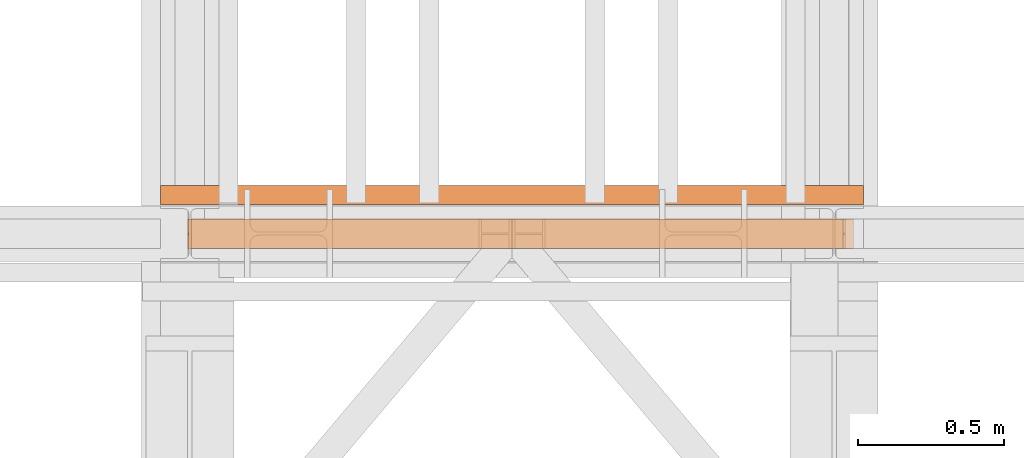
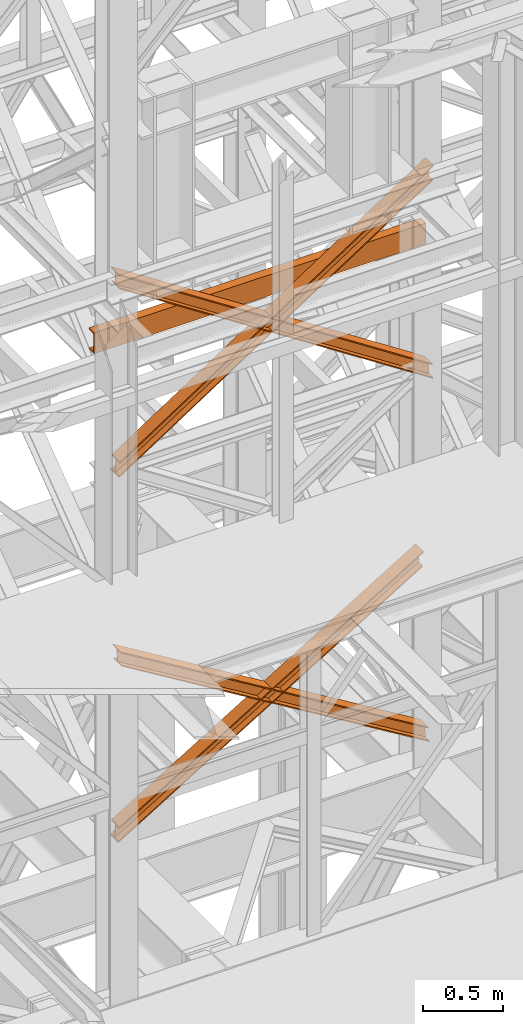
# One storey, part 148 of 208: 5 proxies.
"""IFC2X3 building model written with IfcOpenShell, lengths in millimetres."""

from ifc_helpers import new_model, entity, si_unit, converted_unit, frame, origin, origin_with_axes, place, context, subcontext, project, spatial, faceted_brep, element, save


model = new_model("IFC2X3")

# Units and contexts
model_context = context("Model", 3, precision=1e-05, world=origin())
plan_context = context("Plan", 3, precision=1e-05, world=origin())
body_context = subcontext(model_context, "Body", "Model", "MODEL_VIEW")
ifc_project = project(units=[si_unit("LENGTHUNIT", "METRE", prefix="MILLI"), converted_unit("PLANEANGLEUNIT", "DEGREE", entity("IfcPlaneAngleMeasure", 0.0174532925199433), si_unit("PLANEANGLEUNIT", "RADIAN"), dimensions=[0, 0, 0, 0, 0, 0, 0]), si_unit("AREAUNIT", "SQUARE_METRE"), si_unit("VOLUMEUNIT", "CUBIC_METRE")], contexts=[model_context, plan_context])

# Building, storey
building_placement = place(None, origin())
building = spatial("IfcBuilding", under=ifc_project, at=building_placement, CompositionType="COMPLEX")
storey_placement = place(building_placement, origin_with_axes())
storey = spatial("IfcBuildingStorey", under=building, at=storey_placement, Name="Geschoss", CompositionType="ELEMENT")

# Proxies
proxy_1_placement = place(storey_placement, frame((3296.815108748539, -16012.57439031789, 5416.11849569985), z_axis=(0.0, 0.0, 1.0), x_axis=(1.0, 0.0, 0.0)))
element("IfcBuildingElementProxy", 1, at=proxy_1_placement, inside=storey, context=body_context, shape_type="Brep", body=[
    faceted_brep([(9.078306774576959, 0.00999999999839929, 1356.319280613212), (8.32261454336276, 0.00999999999839929, 1365.972310985451), (2235.078850609916, 0.01000000000021828, 9.663030372239518), (2235.834542841132, 0.01000000000021828, 0.01000000000021828), (9.078306774576959, 100.0099999999984, 1356.319280613212), (9.078306774576959, 0.00999999999839929, 1356.319280613212), (2235.834542841132, 0.01000000000021828, 0.01000000000021828), (2235.834542841132, 100.0100000000002, 0.01000000000021828), (8.32261454336276, 100.0099999999984, 1365.972310985451), (9.078306774576959, 100.0099999999984, 1356.319280613212), (2235.834542841132, 100.0100000000002, 0.01000000000021828), (2235.078850609916, 100.0100000000002, 9.663030372239518), (8.32261454336276, 52.5099999999984, 1365.972310985451), (8.32261454336276, 100.0099999999984, 1365.972310985451), (2235.078850609916, 100.0100000000002, 9.663030372239518), (2235.078850609916, 52.51000000000022, 9.663030372239518), (0.7656922312153256, 52.5099999999984, 1462.502614707844), (8.32261454336276, 52.5099999999984, 1365.972310985451), (2235.078850609916, 52.51000000000022, 9.663030372239518), (2227.521928297769, 52.51000000000022, 106.1933340946398), (0.7656922312135066, 100.0099999999984, 1462.502614707844), (0.7656922312153256, 52.5099999999984, 1462.502614707844), (2227.521928297769, 52.51000000000022, 106.1933340946398), (2227.521928297765, 100.0100000000002, 106.1933340946398), (0.009999999999308784, 100.0099999999984, 1472.155645080084), (0.7656922312135066, 100.0099999999984, 1462.502614707844), (2227.521928297765, 100.0100000000002, 106.1933340946398), (2226.766236066553, 100.0100000000002, 115.8463644668791), (0.01000000000112777, 0.00999999999839929, 1472.155645080084), (0.009999999999308784, 100.0099999999984, 1472.155645080084), (2226.766236066553, 100.0100000000002, 115.8463644668791), (2226.766236066553, 0.01000000000021828, 115.8463644668791), (0.7656922312135066, 0.00999999999839929, 1462.502614707844), (0.01000000000112777, 0.00999999999839929, 1472.155645080084), (2226.766236066553, 0.01000000000021828, 115.8463644668791), (2227.521928297769, 0.01000000000021828, 106.1933340946398), (0.7656922312135066, 47.5099999999984, 1462.502614707844), (0.7656922312135066, 0.00999999999839929, 1462.502614707844), (2227.521928297769, 0.01000000000021828, 106.1933340946398), (2227.521928297769, 47.51000000000022, 106.1933340946398), (8.32261454336276, 47.5099999999984, 1365.972310985451), (0.7656922312135066, 47.5099999999984, 1462.502614707844), (2227.521928297769, 47.51000000000022, 106.1933340946398), (2235.078850609916, 47.51000000000022, 9.663030372239518), (8.32261454336276, 0.00999999999839929, 1365.972310985451), (8.32261454336276, 47.5099999999984, 1365.972310985451), (2235.078850609916, 47.51000000000022, 9.663030372239518), (2235.078850609916, 0.01000000000021828, 9.663030372239518), (8.32261454336276, 0.00999999999839929, 1365.972310985451), (9.078306774576959, 0.00999999999839929, 1356.319280613212), (9.078306774576959, 100.0099999999984, 1356.319280613212), (8.32261454336276, 100.0099999999984, 1365.972310985451), (8.32261454336276, 52.5099999999984, 1365.972310985451), (0.7656922312153256, 52.5099999999984, 1462.502614707844), (0.7656922312135066, 100.0099999999984, 1462.502614707844), (0.009999999999308784, 100.0099999999984, 1472.155645080084), (0.01000000000112777, 0.00999999999839929, 1472.155645080084), (0.7656922312135066, 0.00999999999839929, 1462.502614707844), (0.7656922312135066, 47.5099999999984, 1462.502614707844), (8.32261454336276, 47.5099999999984, 1365.972310985451), (2235.834542841132, 0.01000000000021828, 0.01000000000021828), (2235.078850609916, 0.01000000000021828, 9.663030372239518), (2235.078850609916, 47.51000000000022, 9.663030372239518), (2227.521928297769, 47.51000000000022, 106.1933340946398), (2227.521928297769, 0.01000000000021828, 106.1933340946398), (2226.766236066553, 0.01000000000021828, 115.8463644668791), (2226.766236066553, 100.0100000000002, 115.8463644668791), (2227.521928297765, 100.0100000000002, 106.1933340946398), (2227.521928297769, 52.51000000000022, 106.1933340946398), (2235.078850609916, 52.51000000000022, 9.663030372239518), (2235.078850609916, 100.0100000000002, 9.663030372239518), (2235.834542841132, 100.0100000000002, 0.01000000000021828)], [[[0, 1, 2, 3]], [[4, 5, 6, 7]], [[8, 9, 10, 11]], [[12, 13, 14, 15]], [[16, 17, 18, 19]], [[20, 21, 22, 23]], [[24, 25, 26, 27]], [[28, 29, 30, 31]], [[32, 33, 34, 35]], [[36, 37, 38, 39]], [[40, 41, 42, 43]], [[44, 45, 46, 47]], [[48, 49, 50, 51, 52, 53, 54, 55, 56, 57, 58, 59]], [[60, 61, 62, 63, 64, 65, 66, 67, 68, 69, 70, 71]]], orient=[[False], [False], [False], [False], [False], [False], [False], [False], [False], [False], [False], [False], [False], [False]]),
])
proxy_2_placement = place(storey_placement, frame((3281.320778471448, -16012.57439031789, 5432.838493073343), z_axis=(0.0, 0.0, 1.0), x_axis=(1.0, 0.0, 0.0)))
element("IfcBuildingElementProxy", 2, at=proxy_2_placement, inside=storey, context=body_context, shape_type="Brep", body=[
    faceted_brep([(2199.315743062771, 0.01000000000021828, 1339.599283239715), (0.01000000000021828, 0.01000000000385626, 0.01000000000021828), (0.7656922312144161, 0.01000000000385626, 9.663030372239518), (2200.071435293985, 0.01000000000021828, 1349.252313611954), (2199.315743062771, 100.0100000000002, 1339.599283239715), (0.01000000000021828, 100.0100000000039, 0.01000000000021828), (0.01000000000021828, 0.01000000000385626, 0.01000000000021828), (2199.315743062771, 0.01000000000021828, 1339.599283239715), (2200.071435293985, 100.0100000000002, 1349.252313611954), (0.7656922312144161, 100.0100000000039, 9.663030372239518), (0.01000000000021828, 100.0100000000039, 0.01000000000021828), (2199.315743062771, 100.0100000000002, 1339.599283239715), (2200.071435293985, 52.51000000000022, 1349.252313611954), (0.7656922312144161, 52.51000000000386, 9.663030372239518), (0.7656922312144161, 100.0100000000039, 9.663030372239518), (2200.071435293985, 100.0100000000002, 1349.252313611954), (2207.628357606132, 52.51000000000022, 1445.782617334351), (8.32261454336367, 52.51000000000386, 106.1933340946362), (0.7656922312144161, 52.51000000000386, 9.663030372239518), (2200.071435293985, 52.51000000000022, 1349.252313611954), (2207.628357606134, 100.0100000000002, 1445.782617334351), (8.32261454336549, 100.0100000000039, 106.1933340946362), (8.32261454336367, 52.51000000000386, 106.1933340946362), (2207.628357606132, 52.51000000000022, 1445.782617334351), (2208.384049837348, 100.0100000000002, 1455.43564770659), (9.078306774579687, 100.0100000000039, 115.8463644668791), (8.32261454336549, 100.0100000000039, 106.1933340946362), (2207.628357606134, 100.0100000000002, 1445.782617334351), (2208.384049837347, 0.01000000000021828, 1455.43564770659), (9.078306774579687, 0.01000000000385626, 115.8463644668791), (9.078306774579687, 100.0100000000039, 115.8463644668791), (2208.384049837348, 100.0100000000002, 1455.43564770659), (2207.628357606134, 0.01000000000021828, 1445.782617334351), (8.32261454336367, 0.01000000000385626, 106.1933340946362), (9.078306774579687, 0.01000000000385626, 115.8463644668791), (2208.384049837347, 0.01000000000021828, 1455.43564770659), (2207.628357606134, 47.51000000000022, 1445.782617334351), (8.32261454336367, 47.51000000000386, 106.1933340946362), (8.32261454336367, 0.01000000000385626, 106.1933340946362), (2207.628357606134, 0.01000000000021828, 1445.782617334351), (2200.071435293985, 47.51000000000022, 1349.252313611954), (0.7656922312144161, 47.51000000000386, 9.663030372239518), (8.32261454336367, 47.51000000000386, 106.1933340946362), (2207.628357606134, 47.51000000000022, 1445.782617334351), (2200.071435293985, 0.01000000000021828, 1349.252313611954), (0.7656922312144161, 0.01000000000385626, 9.663030372239518), (0.7656922312144161, 47.51000000000386, 9.663030372239518), (2200.071435293985, 47.51000000000022, 1349.252313611954), (2200.071435293985, 0.01000000000021828, 1349.252313611954), (2200.071435293985, 47.51000000000022, 1349.252313611954), (2207.628357606134, 47.51000000000022, 1445.782617334351), (2207.628357606134, 0.01000000000021828, 1445.782617334351), (2208.384049837347, 0.01000000000021828, 1455.43564770659), (2208.384049837348, 100.0100000000002, 1455.43564770659), (2207.628357606134, 100.0100000000002, 1445.782617334351), (2207.628357606132, 52.51000000000022, 1445.782617334351), (2200.071435293985, 52.51000000000022, 1349.252313611954), (2200.071435293985, 100.0100000000002, 1349.252313611954), (2199.315743062771, 100.0100000000002, 1339.599283239715), (2199.315743062771, 0.01000000000021828, 1339.599283239715), (0.01000000000021828, 0.01000000000385626, 0.01000000000021828), (0.01000000000021828, 100.0100000000039, 0.01000000000021828), (0.7656922312144161, 100.0100000000039, 9.663030372239518), (0.7656922312144161, 52.51000000000386, 9.663030372239518), (8.32261454336367, 52.51000000000386, 106.1933340946362), (8.32261454336549, 100.0100000000039, 106.1933340946362), (9.078306774579687, 100.0100000000039, 115.8463644668791), (9.078306774579687, 0.01000000000385626, 115.8463644668791), (8.32261454336367, 0.01000000000385626, 106.1933340946362), (8.32261454336367, 47.51000000000386, 106.1933340946362), (0.7656922312144161, 47.51000000000386, 9.663030372239518), (0.7656922312144161, 0.01000000000385626, 9.663030372239518)], [[[0, 1, 2, 3]], [[4, 5, 6, 7]], [[8, 9, 10, 11]], [[12, 13, 14, 15]], [[16, 17, 18, 19]], [[20, 21, 22, 23]], [[24, 25, 26, 27]], [[28, 29, 30, 31]], [[32, 33, 34, 35]], [[36, 37, 38, 39]], [[40, 41, 42, 43]], [[44, 45, 46, 47]], [[48, 49, 50, 51, 52, 53, 54, 55, 56, 57, 58, 59]], [[60, 61, 62, 63, 64, 65, 66, 67, 68, 69, 70, 71]]], orient=[[False], [False], [False], [False], [False], [False], [False], [False], [False], [False], [False], [False], [False], [False]]),
])
proxy_3_placement = place(storey_placement, frame((3285.388188692425, -16012.57439031789, 8182.880142734512), z_axis=(0.0, 0.0, 1.0), x_axis=(1.0, 0.0, 0.0)))
element("IfcBuildingElementProxy", 3, at=proxy_3_placement, inside=storey, context=body_context, shape_type="Brep", body=[
    faceted_brep([(5.514462924551481, 0.01000000000021828, 1478.089754817496), (5.055757680838724, 0.01000000000021828, 1487.761448341129), (2271.874000004331, 0.01000000000021828, 9.68169352363293), (2272.332705248044, 0.01000000000021828, 0.01000000000021828), (5.514462924551481, 100.0100000000002, 1478.089754817496), (5.514462924551481, 0.01000000000021828, 1478.089754817496), (2272.332705248044, 0.01000000000021828, 0.01000000000021828), (2272.332705248044, 100.0100000000002, 0.01000000000021828), (5.055757680838724, 100.0100000000002, 1487.761448341129), (5.514462924551481, 100.0100000000002, 1478.089754817496), (2272.332705248044, 100.0100000000002, 0.01000000000021828), (2271.874000004331, 100.0100000000002, 9.68169352363293), (5.055757680838724, 52.51000000000022, 1487.761448341129), (5.055757680838724, 100.0100000000002, 1487.761448341129), (2271.874000004331, 100.0100000000002, 9.68169352363293), (2271.874000004331, 52.51000000000022, 9.68169352363293), (0.4687052437147941, 52.51000000000022, 1584.478383577456), (5.055757680838724, 52.51000000000022, 1487.761448341129), (2271.874000004331, 52.51000000000022, 9.68169352363293), (2267.286947567205, 52.51000000000022, 106.3986287599673), (0.4687052437129751, 100.0100000000002, 1584.478383577456), (0.4687052437147941, 52.51000000000022, 1584.478383577456), (2267.286947567205, 52.51000000000022, 106.3986287599673), (2267.286947567203, 100.0100000000002, 106.3986287599673), (0.01000000000021828, 100.0100000000002, 1594.150077101096), (0.4687052437129751, 100.0100000000002, 1584.478383577456), (2267.286947567203, 100.0100000000002, 106.3986287599673), (2266.828242323492, 100.0100000000002, 116.0703222836), (0.01000000000203727, 0.01000000000021828, 1594.150077101096), (0.01000000000021828, 100.0100000000002, 1594.150077101096), (2266.828242323492, 100.0100000000002, 116.0703222836), (2266.828242323492, 0.01000000000021828, 116.0703222836), (0.4687052437129751, 0.01000000000021828, 1584.478383577456), (0.01000000000203727, 0.01000000000021828, 1594.150077101096), (2266.828242323492, 0.01000000000021828, 116.0703222836), (2267.286947567205, 0.01000000000021828, 106.3986287599673), (0.4687052437129751, 47.51000000000022, 1584.478383577456), (0.4687052437129751, 0.01000000000021828, 1584.478383577456), (2267.286947567205, 0.01000000000021828, 106.3986287599673), (2267.286947567205, 47.51000000000022, 106.3986287599673), (5.055757680838724, 47.51000000000022, 1487.761448341129), (0.4687052437129751, 47.51000000000022, 1584.478383577456), (2267.286947567205, 47.51000000000022, 106.3986287599673), (2271.874000004331, 47.51000000000022, 9.68169352363293), (5.055757680838724, 0.01000000000021828, 1487.761448341129), (5.055757680838724, 47.51000000000022, 1487.761448341129), (2271.874000004331, 47.51000000000022, 9.68169352363293), (2271.874000004331, 0.01000000000021828, 9.68169352363293), (5.055757680838724, 0.01000000000021828, 1487.761448341129), (5.514462924551481, 0.01000000000021828, 1478.089754817496), (5.514462924551481, 100.0100000000002, 1478.089754817496), (5.055757680838724, 100.0100000000002, 1487.761448341129), (5.055757680838724, 52.51000000000022, 1487.761448341129), (0.4687052437147941, 52.51000000000022, 1584.478383577456), (0.4687052437129751, 100.0100000000002, 1584.478383577456), (0.01000000000021828, 100.0100000000002, 1594.150077101096), (0.01000000000203727, 0.01000000000021828, 1594.150077101096), (0.4687052437129751, 0.01000000000021828, 1584.478383577456), (0.4687052437129751, 47.51000000000022, 1584.478383577456), (5.055757680838724, 47.51000000000022, 1487.761448341129), (2272.332705248044, 0.01000000000021828, 0.01000000000021828), (2271.874000004331, 0.01000000000021828, 9.68169352363293), (2271.874000004331, 47.51000000000022, 9.68169352363293), (2267.286947567205, 47.51000000000022, 106.3986287599673), (2267.286947567205, 0.01000000000021828, 106.3986287599673), (2266.828242323492, 0.01000000000021828, 116.0703222836), (2266.828242323492, 100.0100000000002, 116.0703222836), (2267.286947567203, 100.0100000000002, 106.3986287599673), (2267.286947567205, 52.51000000000022, 106.3986287599673), (2271.874000004331, 52.51000000000022, 9.68169352363293), (2271.874000004331, 100.0100000000002, 9.68169352363293), (2272.332705248044, 100.0100000000002, 0.01000000000021828)], [[[0, 1, 2, 3]], [[4, 5, 6, 7]], [[8, 9, 10, 11]], [[12, 13, 14, 15]], [[16, 17, 18, 19]], [[20, 21, 22, 23]], [[24, 25, 26, 27]], [[28, 29, 30, 31]], [[32, 33, 34, 35]], [[36, 37, 38, 39]], [[40, 41, 42, 43]], [[44, 45, 46, 47]], [[48, 49, 50, 51, 52, 53, 54, 55, 56, 57, 58, 59]], [[60, 61, 62, 63, 64, 65, 66, 67, 68, 69, 70, 71]]], orient=[[False], [False], [False], [False], [False], [False], [False], [False], [False], [False], [False], [False], [False], [False]]),
])
proxy_4_placement = place(storey_placement, frame((3287.437718684576, -16012.57439031789, 8221.109787353123), z_axis=(0.0, 0.0, 1.0), x_axis=(1.0, 0.0, 0.0)))
element("IfcBuildingElementProxy", 4, at=proxy_4_placement, inside=storey, context=body_context, shape_type="Brep", body=[
    faceted_brep([(2266.828242323492, 0.01000000000021828, 1478.089754817493), (0.01000000000021828, 0.01000000000203727, 0.01000000000021828), (0.4687052437129751, 0.01000000000203727, 9.68169352363293), (2267.286947567205, 0.01000000000021828, 1487.761448341124), (2266.828242323492, 100.0100000000002, 1478.089754817491), (0.01000000000021828, 100.010000000002, 0.01000000000021828), (0.01000000000021828, 0.01000000000203727, 0.01000000000021828), (2266.828242323492, 0.01000000000021828, 1478.089754817493), (2267.286947567205, 100.0100000000002, 1487.761448341124), (0.4687052437129751, 100.010000000002, 9.68169352363293), (0.01000000000021828, 100.010000000002, 0.01000000000021828), (2266.828242323492, 100.0100000000002, 1478.089754817491), (2267.286947567205, 52.51000000000022, 1487.761448341124), (0.4687052437129751, 52.51000000000204, 9.68169352363293), (0.4687052437129751, 100.010000000002, 9.68169352363293), (2267.286947567205, 100.0100000000002, 1487.761448341124), (2271.874000004329, 52.51000000000022, 1584.478383577458), (5.055757680838724, 52.51000000000022, 106.3986287599673), (0.4687052437129751, 52.51000000000204, 9.68169352363293), (2267.286947567205, 52.51000000000022, 1487.761448341124), (2271.874000004331, 100.0100000000002, 1584.478383577456), (5.055757680840543, 100.0100000000002, 106.3986287599673), (5.055757680838724, 52.51000000000022, 106.3986287599673), (2271.874000004329, 52.51000000000022, 1584.478383577458), (2272.332705248044, 100.0100000000002, 1594.150077101092), (5.514462924551481, 100.0100000000002, 116.0703222836), (5.055757680840543, 100.0100000000002, 106.3986287599673), (2271.874000004331, 100.0100000000002, 1584.478383577456), (2272.332705248042, 0.01000000000021828, 1594.150077101092), (5.514462924551481, 0.01000000000021828, 116.0703222836), (5.514462924551481, 100.0100000000002, 116.0703222836), (2272.332705248044, 100.0100000000002, 1594.150077101092), (2271.874000004331, 0.01000000000021828, 1584.478383577456), (5.055757680838724, 0.01000000000021828, 106.3986287599673), (5.514462924551481, 0.01000000000021828, 116.0703222836), (2272.332705248042, 0.01000000000021828, 1594.150077101092), (2271.874000004331, 47.51000000000022, 1584.478383577456), (5.055757680838724, 47.51000000000022, 106.3986287599673), (5.055757680838724, 0.01000000000021828, 106.3986287599673), (2271.874000004331, 0.01000000000021828, 1584.478383577456), (2267.286947567205, 47.51000000000022, 1487.761448341124), (0.4687052437129751, 47.51000000000204, 9.68169352363293), (5.055757680838724, 47.51000000000022, 106.3986287599673), (2271.874000004331, 47.51000000000022, 1584.478383577456), (2267.286947567205, 0.01000000000021828, 1487.761448341124), (0.4687052437129751, 0.01000000000203727, 9.68169352363293), (0.4687052437129751, 47.51000000000204, 9.68169352363293), (2267.286947567205, 47.51000000000022, 1487.761448341124), (2267.286947567205, 0.01000000000021828, 1487.761448341124), (2267.286947567205, 47.51000000000022, 1487.761448341124), (2271.874000004331, 47.51000000000022, 1584.478383577456), (2271.874000004331, 0.01000000000021828, 1584.478383577456), (2272.332705248042, 0.01000000000021828, 1594.150077101092), (2272.332705248044, 100.0100000000002, 1594.150077101092), (2271.874000004331, 100.0100000000002, 1584.478383577456), (2271.874000004329, 52.51000000000022, 1584.478383577458), (2267.286947567205, 52.51000000000022, 1487.761448341124), (2267.286947567205, 100.0100000000002, 1487.761448341124), (2266.828242323492, 100.0100000000002, 1478.089754817491), (2266.828242323492, 0.01000000000021828, 1478.089754817493), (0.01000000000021828, 0.01000000000203727, 0.01000000000021828), (0.01000000000021828, 100.010000000002, 0.01000000000021828), (0.4687052437129751, 100.010000000002, 9.68169352363293), (0.4687052437129751, 52.51000000000204, 9.68169352363293), (5.055757680838724, 52.51000000000022, 106.3986287599673), (5.055757680840543, 100.0100000000002, 106.3986287599673), (5.514462924551481, 100.0100000000002, 116.0703222836), (5.514462924551481, 0.01000000000021828, 116.0703222836), (5.055757680838724, 0.01000000000021828, 106.3986287599673), (5.055757680838724, 47.51000000000022, 106.3986287599673), (0.4687052437129751, 47.51000000000204, 9.68169352363293), (0.4687052437129751, 0.01000000000203727, 9.68169352363293)], [[[0, 1, 2, 3]], [[4, 5, 6, 7]], [[8, 9, 10, 11]], [[12, 13, 14, 15]], [[16, 17, 18, 19]], [[20, 21, 22, 23]], [[24, 25, 26, 27]], [[28, 29, 30, 31]], [[32, 33, 34, 35]], [[36, 37, 38, 39]], [[40, 41, 42, 43]], [[44, 45, 46, 47]], [[48, 49, 50, 51, 52, 53, 54, 55, 56, 57, 58, 59]], [[60, 61, 62, 63, 64, 65, 66, 67, 68, 69, 70, 71]]], orient=[[False], [False], [False], [False], [False], [False], [False], [False], [False], [False], [False], [False], [False], [False]]),
])
proxy_5_placement = place(storey_placement, frame((3193.302372304859, -15862.57438797436, 9109.989999999998), z_axis=(0.0, 0.0, 1.0), x_axis=(1.0, 0.0, 0.0)))
element("IfcBuildingElementProxy", 5, at=proxy_5_placement, inside=storey, context=body_context, shape_type="Brep", body=[
    faceted_brep([(2399.962597713924, 0.01853275732537441, 160.0100000000002), (0.009999999999308784, 0.00999999999839929, 160.0100000000002), (0.009999999999308784, 65.0099999999984, 160.0100000000002), (2399.962597713924, 65.01853275732537, 160.0100000000002), (2399.962597713924, 65.01853275732537, 160.0100000000002), (0.009999999999308784, 65.0099999999984, 160.0100000000002), (0.009999999999308784, 65.0099999999984, 156.8875719297539), (2399.962597713924, 65.01853275732537, 156.8875719297539), (2399.962597713924, 65.01853275732537, 156.8875719297539), (0.009999999999308784, 65.0099999999984, 156.8875719297539), (0.009999999999308784, 64.76726342282564, 155.2717110918293), (2399.962597713924, 64.77579618015261, 155.2717110918293), (2399.962597713924, 64.77579618015261, 155.2717110918293), (0.009999999999308784, 64.76726342282564, 155.2717110918293), (0.009999999999308784, 64.06053228585733, 153.7984655565542), (2399.962597713924, 64.06906504318067, 153.7984655565542), (2399.962597713924, 64.06906504318067, 153.7984655565542), (0.009999999999308784, 64.06053228585733, 153.7984655565542), (0.009999999999308784, 62.9521516384666, 152.5978732961266), (2399.962597713924, 62.96068439579358, 152.5978732961266), (2399.962597713924, 62.96068439579358, 152.5978732961266), (0.009999999999308784, 62.9521516384666, 152.5978732961266), (0.009999999999308784, 61.5399564114814, 151.7759086082897), (2399.962597713924, 61.54848916880837, 151.7759086082897), (2399.962597713924, 61.54848916880837, 151.7759086082897), (0.009999999999308784, 61.5399564114814, 151.7759086082897), (0.009999999999308784, 59.94859872255256, 151.4050878978051), (2399.962597713924, 59.95713147987954, 151.4050878978051), (2399.962597713924, 59.95713147987954, 151.4050878978051), (0.009999999999308784, 59.94859872255256, 151.4050878978051), (0.009999999999308784, 17.17267516602806, 147.9830140132835), (2399.962597713924, 17.18120792335503, 147.9830140132835), (2399.962597713924, 17.18120792335503, 147.9830140132835), (0.009999999999308784, 17.17267516602806, 147.9830140132835), (0.009999999999308784, 14.20840820800731, 147.318026761528), (2399.962597713924, 14.21694096533429, 147.318026761528), (2399.962597713924, 14.21694096533429, 147.318026761528), (0.009999999999308784, 14.20840820800731, 147.318026761528), (0.009999999999308784, 11.43861959928836, 145.7058782528511), (2399.962597713924, 11.4471523566117, 145.7058782528511), (2399.962597713924, 11.4471523566117, 145.7058782528511), (0.009999999999308784, 11.43861959928836, 145.7058782528511), (0.009999999999308784, 9.322620181545062, 143.4138384829421), (2399.962597713924, 9.331152938872037, 143.4138384829421), (2399.962597713924, 9.331152938872037, 143.4138384829421), (0.009999999999308784, 9.322620181545062, 143.4138384829421), (0.009999999999308784, 7.973406192784751, 140.6012788246917), (2399.962597713924, 7.981938950111726, 140.6012788246917), (2399.962597713924, 7.981938950111726, 140.6012788246917), (0.009999999999308784, 7.973406192784751, 140.6012788246917), (0.009999999999308784, 7.509999999998399, 137.5164535886543), (2399.962597713924, 7.518532757325374, 137.5164535886543), (2399.962597713924, 7.518532757325374, 137.5164535886543), (0.009999999999308784, 7.509999999998399, 137.5164535886543), (0.009999999999308784, 7.509999999998399, 22.503546411348), (2399.962597713924, 7.518532757325374, 22.503546411348), (2399.962597713924, 7.518532757325374, 22.503546411348), (0.009999999999308784, 7.509999999998399, 22.503546411348), (0.009999999999308784, 7.973406192784751, 19.41872117530875), (2399.962597713924, 7.981938950111726, 19.41872117530875), (2399.962597713924, 7.981938950111726, 19.41872117530875), (0.009999999999308784, 7.973406192784751, 19.41872117530875), (0.009999999999308784, 9.322620181545062, 16.60616151705835), (2399.962597713924, 9.331152938872037, 16.60616151705835), (2399.962597713924, 9.331152938872037, 16.60616151705835), (0.009999999999308784, 9.322620181545062, 16.60616151705835), (0.009999999999308784, 11.43861959928836, 14.31412174714933), (2399.962597713924, 11.4471523566117, 14.31412174714933), (2399.962597713924, 11.4471523566117, 14.31412174714933), (0.009999999999308784, 11.43861959928836, 14.31412174714933), (0.009999999999308784, 14.13462866898408, 12.74491643400688), (2399.962597713924, 14.14316142630742, 12.74491643400688), (2399.962597713924, 14.14316142630742, 12.74491643400688), (0.009999999999308784, 14.13462866898408, 12.74491643400688), (0.009999999999308784, 17.17267516602806, 12.03698598671872), (2399.962597713924, 17.18120792335503, 12.03698598671872), (2399.962597713924, 17.18120792335503, 12.03698598671872), (0.009999999999308784, 17.17267516602806, 12.03698598671872), (0.009999999999308784, 59.94859872255256, 8.614912102195376), (2399.962597713924, 59.95713147987954, 8.614912102195376), (2399.962597713924, 59.95713147987954, 8.614912102195376), (0.009999999999308784, 59.94859872255256, 8.614912102195376), (0.009999999999308784, 61.5399564114814, 8.244091391710754), (2399.962597713924, 61.54848916880837, 8.244091391710754), (2399.962597713924, 61.54848916880837, 8.244091391710754), (0.009999999999308784, 61.5399564114814, 8.244091391710754), (0.009999999999308784, 62.9521516384666, 7.422126703873801), (2399.962597713924, 62.96068439579358, 7.422126703873801), (2399.962597713924, 62.96068439579358, 7.422126703873801), (0.009999999999308784, 62.9521516384666, 7.422126703873801), (0.009999999999308784, 64.06053228585733, 6.221534443446217), (2399.962597713924, 64.06906504318067, 6.221534443446217), (2399.962597713924, 64.06906504318067, 6.221534443446217), (0.009999999999308784, 64.06053228585733, 6.221534443446217), (0.009999999999308784, 64.76726342282564, 4.748288908172981), (2399.962597713924, 64.77579618015261, 4.748288908172981), (2399.962597713924, 64.77579618015261, 4.748288908172981), (0.009999999999308784, 64.76726342282564, 4.748288908172981), (0.009999999999308784, 65.0099999999984, 0.01000000000021828), (2399.962597713924, 65.01853275732537, 0.01000000000021828), (2399.962597713924, 65.01853275732537, 0.01000000000021828), (0.009999999999308784, 65.0099999999984, 0.01000000000021828), (0.009999999999308784, 0.00999999999839929, 0.01000000000021828), (2399.962597713924, 0.01853275732537441, 0.01000000000021828), (2399.962597713924, 0.01853275732537441, 0.01000000000021828), (0.009999999999308784, 0.00999999999839929, 0.01000000000021828), (0.009999999999308784, 0.00999999999839929, 160.0100000000002), (2399.962597713924, 0.01853275732537441, 160.0100000000002), (2399.962597713924, 0.01853275732537441, 160.0100000000002), (2399.962597713924, 65.01853275732537, 160.0100000000002), (2399.962597713924, 65.01853275732537, 156.8875719297539), (2399.962597713924, 64.77579618015261, 155.2717110918293), (2399.962597713924, 64.06906504318067, 153.7984655565542), (2399.962597713924, 62.96068439579358, 152.5978732961266), (2399.962597713924, 61.54848916880837, 151.7759086082897), (2399.962597713924, 59.95713147987954, 151.4050878978051), (2399.962597713924, 17.18120792335503, 147.9830140132835), (2399.962597713924, 14.21694096533429, 147.318026761528), (2399.962597713924, 11.4471523566117, 145.7058782528511), (2399.962597713924, 9.331152938872037, 143.4138384829421), (2399.962597713924, 7.981938950111726, 140.6012788246917), (2399.962597713924, 7.518532757325374, 137.5164535886543), (2399.962597713924, 7.518532757325374, 22.503546411348), (2399.962597713924, 7.981938950111726, 19.41872117530875), (2399.962597713924, 9.331152938872037, 16.60616151705835), (2399.962597713924, 11.4471523566117, 14.31412174714933), (2399.962597713924, 14.14316142630742, 12.74491643400688), (2399.962597713924, 17.18120792335503, 12.03698598671872), (2399.962597713924, 59.95713147987954, 8.614912102195376), (2399.962597713924, 61.54848916880837, 8.244091391710754), (2399.962597713924, 62.96068439579358, 7.422126703873801), (2399.962597713924, 64.06906504318067, 6.221534443446217), (2399.962597713924, 64.77579618015261, 4.748288908172981), (2399.962597713924, 65.01853275732537, 0.01000000000021828), (2399.962597713924, 0.01853275732537441, 0.01000000000021828), (0.009999999999308784, 0.00999999999839929, 160.0100000000002), (0.009999999999308784, 0.00999999999839929, 0.01000000000021828), (0.009999999999308784, 65.0099999999984, 0.01000000000021828), (0.009999999999308784, 64.76726342282564, 4.748288908172981), (0.009999999999308784, 64.06053228585733, 6.221534443446217), (0.009999999999308784, 62.9521516384666, 7.422126703873801), (0.009999999999308784, 61.5399564114814, 8.244091391710754), (0.009999999999308784, 59.94859872255256, 8.614912102195376), (0.009999999999308784, 17.17267516602806, 12.03698598671872), (0.009999999999308784, 14.13462866898408, 12.74491643400688), (0.009999999999308784, 11.43861959928836, 14.31412174714933), (0.009999999999308784, 9.322620181545062, 16.60616151705835), (0.009999999999308784, 7.973406192784751, 19.41872117530875), (0.009999999999308784, 7.509999999998399, 22.503546411348), (0.009999999999308784, 7.509999999998399, 137.5164535886543), (0.009999999999308784, 7.973406192784751, 140.6012788246917), (0.009999999999308784, 9.322620181545062, 143.4138384829421), (0.009999999999308784, 11.43861959928836, 145.7058782528511), (0.009999999999308784, 14.20840820800731, 147.318026761528), (0.009999999999308784, 17.17267516602806, 147.9830140132835), (0.009999999999308784, 59.94859872255256, 151.4050878978051), (0.009999999999308784, 61.5399564114814, 151.7759086082897), (0.009999999999308784, 62.9521516384666, 152.5978732961266), (0.009999999999308784, 64.06053228585733, 153.7984655565542), (0.009999999999308784, 64.76726342282564, 155.2717110918293), (0.009999999999308784, 65.0099999999984, 156.8875719297539), (0.009999999999308784, 65.0099999999984, 160.0100000000002)], [[[0, 1, 2, 3]], [[4, 5, 6, 7]], [[8, 9, 10, 11]], [[12, 13, 14, 15]], [[16, 17, 18, 19]], [[20, 21, 22, 23]], [[24, 25, 26, 27]], [[28, 29, 30, 31]], [[32, 33, 34, 35]], [[36, 37, 38, 39]], [[40, 41, 42, 43]], [[44, 45, 46, 47]], [[48, 49, 50, 51]], [[52, 53, 54, 55]], [[56, 57, 58, 59]], [[60, 61, 62, 63]], [[64, 65, 66, 67]], [[68, 69, 70, 71]], [[72, 73, 74, 75]], [[76, 77, 78, 79]], [[80, 81, 82, 83]], [[84, 85, 86, 87]], [[88, 89, 90, 91]], [[92, 93, 94, 95]], [[96, 97, 98, 99]], [[100, 101, 102, 103]], [[104, 105, 106, 107]], [[108, 109, 110, 111, 112, 113, 114, 115, 116, 117, 118, 119, 120, 121, 122, 123, 124, 125, 126, 127, 128, 129, 130, 131, 132, 133, 134]], [[135, 136, 137, 138, 139, 140, 141, 142, 143, 144, 145, 146, 147, 148, 149, 150, 151, 152, 153, 154, 155, 156, 157, 158, 159, 160, 161]]], orient=[[False], [False], [False], [False], [False], [False], [False], [False], [False], [False], [False], [False], [False], [False], [False], [False], [False], [False], [False], [False], [False], [False], [False], [False], [False], [False], [False], [False], [False]]),
])

save(model, "model.ifc")
